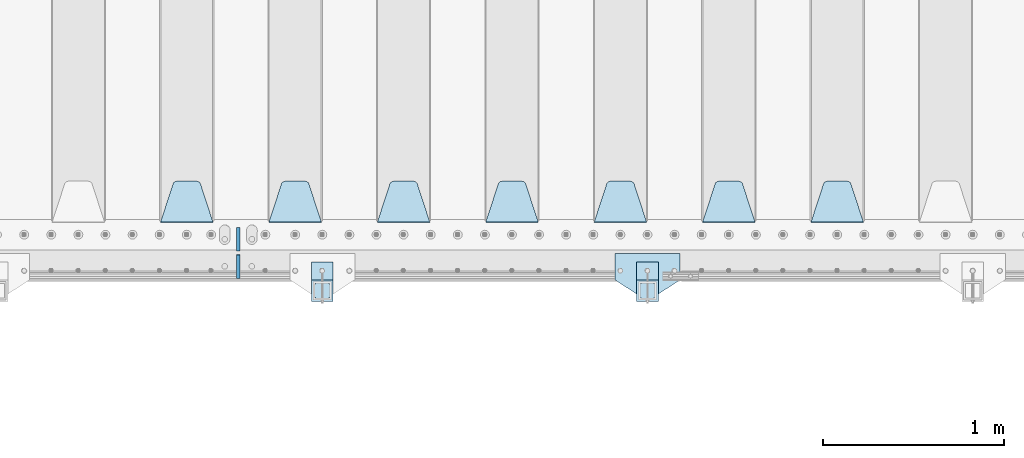
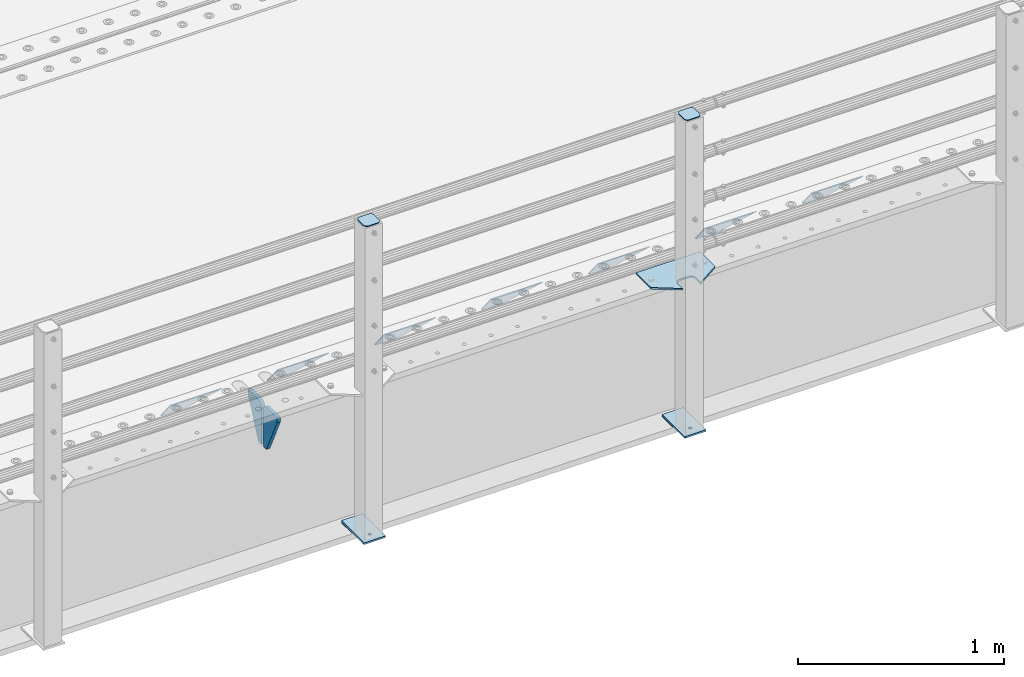
# One storey, part 205 of 242: 16 plates.
"""IFC2X3 building model written with IfcOpenShell, lengths in millimetres."""

from ifc_helpers import new_model, si_unit, frame, origin_with_axes, place, context, subcontext, project, spatial, faceted_brep, material, type_object, element, save


model = new_model("IFC2X3")

# Units and contexts
model_context = context("Model", 3, precision=1e-05, world=origin_with_axes())
body_context = subcontext(model_context, "Body", "Model", "MODEL_VIEW")
ifc_project = project(units=[si_unit("LENGTHUNIT", "METRE", prefix="MILLI"), si_unit("AREAUNIT", "SQUARE_METRE"), si_unit("VOLUMEUNIT", "CUBIC_METRE"), si_unit("MASSUNIT", "GRAM", prefix="KILO"), si_unit("TIMEUNIT", "SECOND"), si_unit("PLANEANGLEUNIT", "RADIAN"), si_unit("SOLIDANGLEUNIT", "STERADIAN"), si_unit("THERMODYNAMICTEMPERATUREUNIT", "DEGREE_CELSIUS"), si_unit("LUMINOUSINTENSITYUNIT", "LUMEN")], contexts=[model_context])

# Site, building, storey
site_placement = place(None, origin_with_axes())
site = spatial("IfcSite", under=ifc_project, at=site_placement, CompositionType="ELEMENT")
building_placement = place(site_placement, origin_with_axes())
building = spatial("IfcBuilding", under=site, at=building_placement, Name="Standard", CompositionType="ELEMENT")
storey_placement = place(building_placement, origin_with_axes())
storey = spatial("IfcBuildingStorey", under=building, at=storey_placement, Name="Undefined", CompositionType="ELEMENT", Elevation=0.0)

# Plates
ifc_material_1 = material(Name="STEEL/S355J2")
plate_type_1 = type_object("IfcPlateType", PredefinedType="NOTDEFINED")
plate_1_placement = place(storey_placement, frame((-32720.0, -24005.0, 5.00000000004911), z_axis=(0.0, -1.0, 0.0), x_axis=(-1.0, 0.0, 0.0)))
element("IfcPlate", 1, at=plate_1_placement, inside=storey, type_object=plate_type_1, material=ifc_material_1, context=body_context, shape_type="Brep", body=[
    faceted_brep([(0.0, -5.0, 0.0), (2.31396552408114e-06, -5.0, 145.0), (2.31396552408114e-06, 5.0, 145.0), (0.0, 5.0, 0.0), (130.0, -5.0, 230.0), (130.0, 5.0, 230.0), (130.0, -5.0, 180.0), (130.0, 5.0, 180.0), (130.48036798992, -5.0, 175.122741949595), (130.48036798992, 5.0, 175.122741949595), (131.903011687216, -5.0, 170.432914190871), (131.903011687216, 5.0, 170.432914190871), (134.213259692435, -5.0, 166.110744174512), (134.213259692435, 5.0, 166.110744174512), (137.322330470335, -5.0, 162.322330470335), (137.322330470335, 5.0, 162.322330470335), (141.110744174512, -5.0, 159.213259692435), (141.110744174512, 5.0, 159.213259692435), (145.432914190871, -5.0, 156.903011687216), (145.432914190871, 5.0, 156.903011687216), (150.122741949595, -5.0, 155.48036798992), (150.122741949595, 5.0, 155.48036798992), (155.0, -5.0, 155.0), (155.0, 5.0, 155.0), (205.0, -5.0, 155.0), (205.0, 5.0, 155.0), (209.877258050405, -5.0, 155.48036798992), (209.877258050405, 5.0, 155.48036798992), (214.567085809129, -5.0, 156.903011687216), (214.567085809129, 5.0, 156.903011687216), (218.889255825488, -5.0, 159.213259692435), (218.889255825488, 5.0, 159.213259692435), (222.677669529665, -5.0, 162.322330470335), (222.677669529665, 5.0, 162.322330470335), (225.786740307565, -5.0, 166.110744174512), (225.786740307565, 5.0, 166.110744174512), (228.096988312784, -5.0, 170.432914190871), (228.096988312784, 5.0, 170.432914190871), (229.51963201008, -5.0, 175.122741949595), (229.51963201008, 5.0, 175.122741949595), (230.0, -5.0, 180.0), (230.0, 5.0, 180.0), (230.0, -5.0, 230.0), (230.0, 5.0, 230.0), (360.0, -5.0, 145.0), (360.0, 5.0, 145.0), (360.0, -5.0, -7.27595761418343e-12), (360.0, 5.0, -7.27595761418343e-12)], [[[0, 1, 2, 3]], [[1, 4, 5, 2]], [[4, 6, 7, 5]], [[6, 8, 9, 7]], [[8, 10, 11, 9]], [[10, 12, 13, 11]], [[12, 14, 15, 13]], [[14, 16, 17, 15]], [[16, 18, 19, 17]], [[18, 20, 21, 19]], [[20, 22, 23, 21]], [[22, 24, 25, 23]], [[24, 26, 27, 25]], [[26, 28, 29, 27]], [[28, 30, 31, 29]], [[30, 32, 33, 31]], [[32, 34, 35, 33]], [[34, 36, 37, 35]], [[36, 38, 39, 37]], [[38, 40, 41, 39]], [[40, 42, 43, 41]], [[42, 44, 45, 43]], [[44, 46, 47, 45]], [[46, 0, 3, 47]], [[5, 7, 9, 11, 13, 15, 17, 19, 21, 23, 25, 27, 29, 31, 33, 35, 37, 39, 41, 43, 45, 47, 3, 2]], [[46, 44, 42, 40, 38, 36, 34, 32, 30, 28, 26, 24, 22, 20, 18, 16, 14, 12, 10, 8, 6, 4, 1, 0]]]),
])
plate_type_2 = type_object("IfcPlateType", PredefinedType="NOTDEFINED")
for number, where, z_axis, x_axis in (
    (2, (-32840.0000000001, -24050.0000000002, -850.000000000002), (0.0, -1.0, 0.0), (-1.0, 0.0, 0.0)),
    (3, (-34640.0000000001, -24050.0000000002, -850.000000000002), (0.0, -1.0, 0.0), (-1.0, 0.0, 0.0)),
):
    element("IfcPlate", number, at=place(storey_placement, frame(where, z_axis=z_axis, x_axis=x_axis)), inside=storey, type_object=plate_type_2, material=ifc_material_1, context=body_context, shape_type="Brep", body=[
        faceted_brep([(53.6360389691836, -5.0, 176.363961030471), (53.6360389691836, 5.0, 176.363961030471), (59.9999999998618, 5.0, 178.999999999793), (59.9999999998618, -5.0, 178.999999999793), (66.3639610305399, 5.0, 176.363961030471), (66.3639610305399, -5.0, 176.363961030471), (68.9999999998618, 5.0, 169.999999999793), (68.9999999998618, -5.0, 169.999999999793), (66.3639610305399, 5.0, 163.636038969114), (66.3639610305399, -5.0, 163.636038969114), (59.9999999998618, 5.0, 160.999999999793), (59.9999999998618, -5.0, 160.999999999793), (53.6360389691836, 5.0, 163.636038969114), (53.6360389691836, -5.0, 163.636038969114), (50.9999999998618, 5.0, 169.999999999793), (50.9999999998618, -5.0, 169.999999999793), (120.0, -5.0, 0.0), (120.0, -5.0, 220.0), (0.0, -5.0, 220.0), (0.0, -5.0, 0.0), (0.0, 5.0, 0.0), (120.0, 5.0, 0.0), (120.0, 5.0, 220.0), (0.0, 5.0, 220.0)], [[[0, 1, 2, 3]], [[3, 2, 4, 5]], [[5, 4, 6, 7]], [[7, 6, 8, 9]], [[9, 8, 10, 11]], [[11, 10, 12, 13]], [[13, 12, 14, 15]], [[15, 14, 1, 0]], [[16, 17, 18, 19], [3, 5, 7, 9, 11, 13, 15, 0]], [[16, 19, 20, 21]], [[17, 16, 21, 22]], [[18, 17, 22, 23]], [[19, 18, 23, 20]], [[22, 21, 20, 23], [10, 8, 6, 4, 2, 1, 14, 12]]]),
    ])
plate_type_3 = type_object("IfcPlateType", PredefinedType="NOTDEFINED")
plate_2_placement = place(storey_placement, frame((-32944.0000000001, -24166.0000000002, 1012.50000000001), z_axis=(0.0, -1.0, 0.0), x_axis=(1.0, 0.0, 0.0)))
element("IfcPlate", 4, at=plate_2_placement, inside=storey, type_object=plate_type_3, material=ifc_material_1, context=body_context, shape_type="Brep", body=[
    faceted_brep([(0.0, -2.5, 19.0), (0.0, -2.5, 69.0), (0.0, 2.5, 69.0), (0.0, 2.5, 19.0), (0.476369668544066, -2.5, 73.2278977451715), (0.476369668544066, 2.5, 73.2278977451715), (1.88159150985302, -2.5, 77.2437910432345), (1.88159150985302, 2.5, 77.2437910432345), (4.14520183310742, -2.5, 80.8463062353148), (4.14520183310742, 2.5, 80.8463062353148), (7.15369376468516, -2.5, 83.8547981668926), (7.15369376468516, 2.5, 83.8547981668926), (10.7562089567655, -2.5, 86.118408490147), (10.7562089567655, 2.5, 86.118408490147), (14.7721022548285, -2.5, 87.5236303314559), (14.7721022548285, 2.5, 87.5236303314559), (19.0, -2.5, 88.0), (19.0, 2.5, 88.0), (69.0, -2.5, 88.0), (69.0, 2.5, 88.0), (73.2278977451715, -2.5, 87.5236303314559), (73.2278977451715, 2.5, 87.5236303314559), (77.2437910432345, -2.5, 86.118408490147), (77.2437910432345, 2.5, 86.118408490147), (80.8463062353148, -2.5, 83.8547981668926), (80.8463062353148, 2.5, 83.8547981668926), (83.8547981668926, -2.5, 80.8463062353148), (83.8547981668926, 2.5, 80.8463062353148), (86.118408490147, -2.5, 77.2437910432345), (86.118408490147, 2.5, 77.2437910432345), (87.5236303314559, -2.5, 73.2278977451715), (87.5236303314559, 2.5, 73.2278977451715), (88.0, -2.5, 69.0), (88.0, 2.5, 69.0), (88.0, -2.5, 19.0), (88.0, 2.5, 19.0), (87.5236303314559, -2.5, 14.7721022548285), (87.5236303314559, 2.5, 14.7721022548285), (86.118408490147, -2.5, 10.7562089567655), (86.118408490147, 2.5, 10.7562089567655), (83.8547981668926, -2.5, 7.15369376468516), (83.8547981668926, 2.5, 7.15369376468516), (80.8463062353148, -2.5, 4.14520183310742), (80.8463062353148, 2.5, 4.14520183310742), (77.2437910432345, -2.5, 1.88159150985302), (77.2437910432345, 2.5, 1.88159150985302), (73.2278977451715, -2.5, 0.476369668544066), (73.2278977451715, 2.5, 0.476369668544066), (69.0, -2.5, 0.0), (69.0, 2.5, 0.0), (19.0, -2.5, 0.0), (19.0, 2.5, 0.0), (14.7721022548285, -2.5, 0.476369668544066), (14.7721022548285, 2.5, 0.476369668544066), (10.7562089567655, -2.5, 1.88159150985302), (10.7562089567655, 2.5, 1.88159150985302), (7.15369376468516, -2.5, 4.14520183310742), (7.15369376468516, 2.5, 4.14520183310742), (4.14520183310742, -2.5, 7.15369376468516), (4.14520183310742, 2.5, 7.15369376468516), (1.88159150985302, -2.5, 10.7562089567655), (1.88159150985302, 2.5, 10.7562089567655), (0.476369668544066, -2.5, 14.7721022548285), (0.476369668544066, 2.5, 14.7721022548285)], [[[0, 1, 2, 3]], [[1, 4, 5, 2]], [[4, 6, 7, 5]], [[6, 8, 9, 7]], [[8, 10, 11, 9]], [[10, 12, 13, 11]], [[12, 14, 15, 13]], [[14, 16, 17, 15]], [[16, 18, 19, 17]], [[18, 20, 21, 19]], [[20, 22, 23, 21]], [[22, 24, 25, 23]], [[24, 26, 27, 25]], [[26, 28, 29, 27]], [[28, 30, 31, 29]], [[30, 32, 33, 31]], [[32, 34, 35, 33]], [[34, 36, 37, 35]], [[36, 38, 39, 37]], [[38, 40, 41, 39]], [[40, 42, 43, 41]], [[42, 44, 45, 43]], [[44, 46, 47, 45]], [[46, 48, 49, 47]], [[48, 50, 51, 49]], [[50, 52, 53, 51]], [[52, 54, 55, 53]], [[54, 56, 57, 55]], [[56, 58, 59, 57]], [[58, 60, 61, 59]], [[60, 62, 63, 61]], [[62, 0, 3, 63]], [[5, 7, 9, 11, 13, 15, 17, 19, 21, 23, 25, 27, 29, 31, 33, 35, 37, 39, 41, 43, 45, 47, 49, 51, 53, 55, 57, 59, 61, 63, 3, 2]], [[62, 60, 58, 56, 54, 52, 50, 48, 46, 44, 42, 40, 38, 36, 34, 32, 30, 28, 26, 24, 22, 20, 18, 16, 14, 12, 10, 8, 6, 4, 1, 0]]]),
])
plate_3_placement = place(storey_placement, frame((-34744.0000000001, -24166.0000000002, 1012.50000000001), z_axis=(0.0, -1.0, 0.0), x_axis=(1.0, 0.0, 0.0)))
element("IfcPlate", 5, at=plate_3_placement, inside=storey, type_object=plate_type_3, material=ifc_material_1, context=body_context, shape_type="Brep", body=[
    faceted_brep([(0.0, -2.5, 19.0), (0.0, -2.5, 69.0), (0.0, 2.5, 69.0), (0.0, 2.5, 19.0), (0.476369668544066, -2.5, 73.2278977451715), (0.476369668544066, 2.5, 73.2278977451715), (1.88159150985302, -2.5, 77.2437910432345), (1.88159150985302, 2.5, 77.2437910432345), (4.14520183310742, -2.5, 80.8463062353148), (4.14520183310742, 2.5, 80.8463062353148), (7.15369376468516, -2.5, 83.8547981668926), (7.15369376468516, 2.5, 83.8547981668926), (10.7562089567655, -2.5, 86.118408490147), (10.7562089567655, 2.5, 86.118408490147), (14.7721022548285, -2.5, 87.5236303314559), (14.7721022548285, 2.5, 87.5236303314559), (19.0, -2.5, 88.0), (19.0, 2.5, 88.0), (69.0, -2.5, 88.0), (69.0, 2.5, 88.0), (73.2278977451715, -2.5, 87.5236303314559), (73.2278977451715, 2.5, 87.5236303314559), (77.2437910432345, -2.5, 86.118408490147), (77.2437910432345, 2.5, 86.118408490147), (80.8463062353148, -2.5, 83.8547981668926), (80.8463062353148, 2.5, 83.8547981668926), (83.8547981668926, -2.5, 80.8463062353148), (83.8547981668926, 2.5, 80.8463062353148), (86.118408490147, -2.5, 77.2437910432345), (86.118408490147, 2.5, 77.2437910432345), (87.5236303314559, -2.5, 73.2278977451715), (87.5236303314559, 2.5, 73.2278977451715), (88.0, -2.5, 69.0), (88.0, 2.5, 69.0), (88.0, -2.5, 19.0), (88.0, 2.5, 19.0), (87.5236303314559, -2.5, 14.7721022548285), (87.5236303314559, 2.5, 14.7721022548285), (86.118408490147, -2.5, 10.7562089567655), (86.118408490147, 2.5, 10.7562089567655), (83.8547981668926, -2.5, 7.15369376468516), (83.8547981668926, 2.5, 7.15369376468516), (80.8463062353148, -2.5, 4.14520183310742), (80.8463062353148, 2.5, 4.14520183310742), (77.2437910432345, -2.5, 1.88159150985302), (77.2437910432345, 2.5, 1.88159150985302), (73.2278977451715, -2.5, 0.476369668544066), (73.2278977451715, 2.5, 0.476369668544066), (69.0, -2.5, 0.0), (69.0, 2.5, 0.0), (19.0, -2.5, 0.0), (19.0, 2.5, 0.0), (14.7721022548285, -2.5, 0.476369668544066), (14.7721022548285, 2.5, 0.476369668544066), (10.7562089567655, -2.5, 1.88159150985302), (10.7562089567655, 2.5, 1.88159150985302), (7.15369376468516, -2.5, 4.14520183310742), (7.15369376468516, 2.5, 4.14520183310742), (4.14520183310742, -2.5, 7.15369376468516), (4.14520183310742, 2.5, 7.15369376468516), (1.88159150985302, -2.5, 10.7562089567655), (1.88159150985302, 2.5, 10.7562089567655), (0.476369668544066, -2.5, 14.7721022548285), (0.476369668544066, 2.5, 14.7721022548285)], [[[0, 1, 2, 3]], [[1, 4, 5, 2]], [[4, 6, 7, 5]], [[6, 8, 9, 7]], [[8, 10, 11, 9]], [[10, 12, 13, 11]], [[12, 14, 15, 13]], [[14, 16, 17, 15]], [[16, 18, 19, 17]], [[18, 20, 21, 19]], [[20, 22, 23, 21]], [[22, 24, 25, 23]], [[24, 26, 27, 25]], [[26, 28, 29, 27]], [[28, 30, 31, 29]], [[30, 32, 33, 31]], [[32, 34, 35, 33]], [[34, 36, 37, 35]], [[36, 38, 39, 37]], [[38, 40, 41, 39]], [[40, 42, 43, 41]], [[42, 44, 45, 43]], [[44, 46, 47, 45]], [[46, 48, 49, 47]], [[48, 50, 51, 49]], [[50, 52, 53, 51]], [[52, 54, 55, 53]], [[54, 56, 57, 55]], [[56, 58, 59, 57]], [[58, 60, 61, 59]], [[60, 62, 63, 61]], [[62, 0, 3, 63]], [[5, 7, 9, 11, 13, 15, 17, 19, 21, 23, 25, 27, 29, 31, 33, 35, 37, 39, 41, 43, 45, 47, 49, 51, 53, 55, 57, 59, 61, 63, 3, 2]], [[62, 60, 58, 56, 54, 52, 50, 48, 46, 44, 42, 40, 38, 36, 34, 32, 30, 28, 26, 24, 22, 20, 18, 16, 14, 12, 10, 8, 6, 4, 1, 0]]]),
])
plate_type_4 = type_object("IfcPlateType", PredefinedType="NOTDEFINED")
for number, where, z_axis, x_axis in (
    (6, (-32840.0000000001, -24050.0000000002, -857.500000000002), (0.0, -1.0, 0.0), (-1.0, 0.0, 0.0)),
    (7, (-34640.0000000001, -24050.0000000002, -857.500000000002), (0.0, -1.0, 0.0), (-1.0, 0.0, 0.0)),
):
    element("IfcPlate", number, at=place(storey_placement, frame(where, z_axis=z_axis, x_axis=x_axis)), inside=storey, type_object=plate_type_4, material=ifc_material_1, context=body_context, shape_type="Brep", body=[
        faceted_brep([(0.0, -2.5, 0.0), (0.0, -2.5, 100.0), (0.0, 2.5, 100.0), (0.0, 2.5, 0.0), (120.0, -2.5, 100.0), (120.0, 2.5, 100.0), (120.0, -2.5, 0.0), (120.0, 2.5, 0.0)], [[[0, 1, 2, 3]], [[1, 4, 5, 2]], [[4, 6, 7, 5]], [[6, 0, 3, 7]], [[5, 7, 3, 2]], [[6, 4, 1, 0]]]),
    ])
ifc_material_2 = material(Name="STEEL/S355N")
plate_type_5 = type_object("IfcPlateType", PredefinedType="NOTDEFINED")
plate_4_placement = place(storey_placement, frame((-31705.0, -23831.767766953, -1.76776695296758), z_axis=(0.0, 0.707106781186547, -0.707106781186548), x_axis=(-1.0, 0.0, 0.0)))
element("IfcPlate", 8, at=plate_4_placement, inside=storey, type_object=plate_type_5, material=ifc_material_2, context=body_context, shape_type="Brep", body=[
    faceted_brep([(0.0, -2.5, 0.0), (69.345504679477, -2.50000000000182, 300.171731424829), (69.345504679477, 2.5, 300.171731424829), (0.0, 2.5, 0.0), (70.9274061199576, -2.5, 304.897442415398), (70.9274061199576, 2.5, 304.897442415398), (73.3818627772307, -2.5, 309.234538108525), (73.3818627772307, 2.50000000000182, 309.234538108529), (76.6187032999551, -2.5, 313.023683126101), (76.6187032999551, 2.50000000000182, 313.023683126103), (80.5190132704993, -2.5, 316.12567259537), (80.5190132704993, 2.5, 316.12567259537), (84.9395038596849, -2.5, 318.426546230474), (84.9395038596849, 2.50000000000182, 318.426546230476), (89.7177759439219, -2.49999999999818, 319.841774983273), (89.7177759439219, 2.50000000000182, 319.841774983273), (94.678286292652, -2.5, 320.319366455076), (94.678286292652, 2.5, 320.319366455076), (195.321713707348, -2.5, 320.319366455076), (195.321713707348, 2.5, 320.319366455076), (200.282224056078, -2.5, 319.841774983272), (200.282224056078, 2.50000000000182, 319.841774983273), (205.060496140315, -2.5, 318.426546230474), (205.060496140315, 2.49999999999818, 318.426546230474), (209.480986729501, -2.49999999999818, 316.12567259537), (209.480986729501, 2.5, 316.12567259537), (213.381296700045, -2.5, 313.023683126101), (213.381296700045, 2.49999999999818, 313.023683126101), (216.618137222769, -2.5, 309.234538108525), (216.618137222769, 2.5, 309.234538108523), (219.072593880042, -2.49999999999818, 304.897442415398), (219.072593880042, 2.50000000000182, 304.897442415398), (220.654495320523, -2.50000000000182, 300.171731424829), (220.654495320523, 2.5, 300.171731424829), (290.0, -2.5, 0.0), (290.0, 2.5, -1.81898940354586e-12)], [[[0, 1, 2, 3]], [[1, 4, 5, 2]], [[4, 6, 7, 5]], [[6, 8, 9, 7]], [[8, 10, 11, 9]], [[10, 12, 13, 11]], [[12, 14, 15, 13]], [[14, 16, 17, 15]], [[16, 18, 19, 17]], [[18, 20, 21, 19]], [[20, 22, 23, 21]], [[22, 24, 25, 23]], [[24, 26, 27, 25]], [[26, 28, 29, 27]], [[28, 30, 31, 29]], [[30, 32, 33, 31]], [[32, 34, 35, 33]], [[34, 0, 3, 35]], [[5, 7, 9, 11, 13, 15, 17, 19, 21, 23, 25, 27, 29, 31, 33, 35, 3, 2]], [[34, 32, 30, 28, 26, 24, 22, 20, 18, 16, 14, 12, 10, 8, 6, 4, 1, 0]]]),
])
plate_5_placement = place(storey_placement, frame((-32305.0, -23831.767766953, -1.76776695296758), z_axis=(0.0, 0.707106781186547, -0.707106781186548), x_axis=(-1.0, 0.0, 0.0)))
element("IfcPlate", 9, at=plate_5_placement, inside=storey, type_object=plate_type_5, material=ifc_material_2, context=body_context, shape_type="Brep", body=[
    faceted_brep([(0.0, -2.5, 0.0), (69.345504679477, -2.50000000000182, 300.171731424829), (69.345504679477, 2.5, 300.171731424829), (0.0, 2.5, 0.0), (70.9274061199576, -2.5, 304.897442415398), (70.9274061199576, 2.5, 304.897442415398), (73.3818627772307, -2.5, 309.234538108525), (73.3818627772307, 2.50000000000182, 309.234538108529), (76.6187032999551, -2.5, 313.023683126101), (76.6187032999551, 2.50000000000182, 313.023683126103), (80.5190132704993, -2.5, 316.12567259537), (80.5190132704993, 2.5, 316.12567259537), (84.9395038596849, -2.5, 318.426546230474), (84.9395038596849, 2.50000000000182, 318.426546230476), (89.7177759439219, -2.49999999999818, 319.841774983273), (89.7177759439219, 2.50000000000182, 319.841774983273), (94.678286292652, -2.5, 320.319366455076), (94.678286292652, 2.5, 320.319366455076), (195.321713707348, -2.5, 320.319366455076), (195.321713707348, 2.5, 320.319366455076), (200.282224056078, -2.5, 319.841774983272), (200.282224056078, 2.50000000000182, 319.841774983273), (205.060496140315, -2.5, 318.426546230474), (205.060496140315, 2.49999999999818, 318.426546230474), (209.480986729501, -2.49999999999818, 316.12567259537), (209.480986729501, 2.5, 316.12567259537), (213.381296700045, -2.5, 313.023683126101), (213.381296700045, 2.49999999999818, 313.023683126101), (216.618137222769, -2.5, 309.234538108525), (216.618137222769, 2.5, 309.234538108523), (219.072593880042, -2.49999999999818, 304.897442415398), (219.072593880042, 2.50000000000182, 304.897442415398), (220.654495320523, -2.50000000000182, 300.171731424829), (220.654495320523, 2.5, 300.171731424829), (290.0, -2.5, 0.0), (290.0, 2.5, -1.81898940354586e-12)], [[[0, 1, 2, 3]], [[1, 4, 5, 2]], [[4, 6, 7, 5]], [[6, 8, 9, 7]], [[8, 10, 11, 9]], [[10, 12, 13, 11]], [[12, 14, 15, 13]], [[14, 16, 17, 15]], [[16, 18, 19, 17]], [[18, 20, 21, 19]], [[20, 22, 23, 21]], [[22, 24, 25, 23]], [[24, 26, 27, 25]], [[26, 28, 29, 27]], [[28, 30, 31, 29]], [[30, 32, 33, 31]], [[32, 34, 35, 33]], [[34, 0, 3, 35]], [[5, 7, 9, 11, 13, 15, 17, 19, 21, 23, 25, 27, 29, 31, 33, 35, 3, 2]], [[34, 32, 30, 28, 26, 24, 22, 20, 18, 16, 14, 12, 10, 8, 6, 4, 1, 0]]]),
])
plate_6_placement = place(storey_placement, frame((-32905.0, -23831.767766953, -1.76776695296758), z_axis=(0.0, 0.707106781186547, -0.707106781186548), x_axis=(-1.0, 0.0, 0.0)))
element("IfcPlate", 10, at=plate_6_placement, inside=storey, type_object=plate_type_5, material=ifc_material_2, context=body_context, shape_type="Brep", body=[
    faceted_brep([(0.0, -2.5, 0.0), (69.345504679477, -2.50000000000182, 300.171731424829), (69.345504679477, 2.5, 300.171731424829), (0.0, 2.5, 0.0), (70.9274061199576, -2.5, 304.897442415398), (70.9274061199576, 2.5, 304.897442415398), (73.3818627772307, -2.5, 309.234538108525), (73.3818627772307, 2.50000000000182, 309.234538108529), (76.6187032999551, -2.5, 313.023683126101), (76.6187032999551, 2.50000000000182, 313.023683126103), (80.5190132704993, -2.5, 316.12567259537), (80.5190132704993, 2.5, 316.12567259537), (84.9395038596849, -2.5, 318.426546230474), (84.9395038596849, 2.50000000000182, 318.426546230476), (89.7177759439219, -2.49999999999818, 319.841774983273), (89.7177759439219, 2.50000000000182, 319.841774983273), (94.678286292652, -2.5, 320.319366455076), (94.678286292652, 2.5, 320.319366455076), (195.321713707348, -2.5, 320.319366455076), (195.321713707348, 2.5, 320.319366455076), (200.282224056078, -2.5, 319.841774983272), (200.282224056078, 2.50000000000182, 319.841774983273), (205.060496140315, -2.5, 318.426546230474), (205.060496140315, 2.49999999999818, 318.426546230474), (209.480986729501, -2.49999999999818, 316.12567259537), (209.480986729501, 2.5, 316.12567259537), (213.381296700045, -2.5, 313.023683126101), (213.381296700045, 2.49999999999818, 313.023683126101), (216.618137222769, -2.5, 309.234538108525), (216.618137222769, 2.5, 309.234538108523), (219.072593880042, -2.49999999999818, 304.897442415398), (219.072593880042, 2.50000000000182, 304.897442415398), (220.654495320523, -2.50000000000182, 300.171731424829), (220.654495320523, 2.5, 300.171731424829), (290.0, -2.5, 0.0), (290.0, 2.5, -1.81898940354586e-12)], [[[0, 1, 2, 3]], [[1, 4, 5, 2]], [[4, 6, 7, 5]], [[6, 8, 9, 7]], [[8, 10, 11, 9]], [[10, 12, 13, 11]], [[12, 14, 15, 13]], [[14, 16, 17, 15]], [[16, 18, 19, 17]], [[18, 20, 21, 19]], [[20, 22, 23, 21]], [[22, 24, 25, 23]], [[24, 26, 27, 25]], [[26, 28, 29, 27]], [[28, 30, 31, 29]], [[30, 32, 33, 31]], [[32, 34, 35, 33]], [[34, 0, 3, 35]], [[5, 7, 9, 11, 13, 15, 17, 19, 21, 23, 25, 27, 29, 31, 33, 35, 3, 2]], [[34, 32, 30, 28, 26, 24, 22, 20, 18, 16, 14, 12, 10, 8, 6, 4, 1, 0]]]),
])
plate_7_placement = place(storey_placement, frame((-33505.0, -23831.767766953, -1.76776695296758), z_axis=(0.0, 0.707106781186547, -0.707106781186548), x_axis=(-1.0, 0.0, 0.0)))
element("IfcPlate", 11, at=plate_7_placement, inside=storey, type_object=plate_type_5, material=ifc_material_2, context=body_context, shape_type="Brep", body=[
    faceted_brep([(0.0, -2.5, 0.0), (69.345504679477, -2.50000000000182, 300.171731424829), (69.345504679477, 2.5, 300.171731424829), (0.0, 2.5, 0.0), (70.9274061199576, -2.5, 304.897442415398), (70.9274061199576, 2.5, 304.897442415398), (73.3818627772307, -2.5, 309.234538108525), (73.3818627772307, 2.50000000000182, 309.234538108529), (76.6187032999551, -2.5, 313.023683126101), (76.6187032999551, 2.50000000000182, 313.023683126103), (80.5190132704993, -2.5, 316.12567259537), (80.5190132704993, 2.5, 316.12567259537), (84.9395038596849, -2.5, 318.426546230474), (84.9395038596849, 2.50000000000182, 318.426546230476), (89.7177759439219, -2.49999999999818, 319.841774983273), (89.7177759439219, 2.50000000000182, 319.841774983273), (94.678286292652, -2.5, 320.319366455076), (94.678286292652, 2.5, 320.319366455076), (195.321713707348, -2.5, 320.319366455076), (195.321713707348, 2.5, 320.319366455076), (200.282224056078, -2.5, 319.841774983272), (200.282224056078, 2.50000000000182, 319.841774983273), (205.060496140315, -2.5, 318.426546230474), (205.060496140315, 2.49999999999818, 318.426546230474), (209.480986729501, -2.49999999999818, 316.12567259537), (209.480986729501, 2.5, 316.12567259537), (213.381296700045, -2.5, 313.023683126101), (213.381296700045, 2.49999999999818, 313.023683126101), (216.618137222769, -2.5, 309.234538108525), (216.618137222769, 2.5, 309.234538108523), (219.072593880042, -2.49999999999818, 304.897442415398), (219.072593880042, 2.50000000000182, 304.897442415398), (220.654495320523, -2.50000000000182, 300.171731424829), (220.654495320523, 2.5, 300.171731424829), (290.0, -2.5, 0.0), (290.0, 2.5, -1.81898940354586e-12)], [[[0, 1, 2, 3]], [[1, 4, 5, 2]], [[4, 6, 7, 5]], [[6, 8, 9, 7]], [[8, 10, 11, 9]], [[10, 12, 13, 11]], [[12, 14, 15, 13]], [[14, 16, 17, 15]], [[16, 18, 19, 17]], [[18, 20, 21, 19]], [[20, 22, 23, 21]], [[22, 24, 25, 23]], [[24, 26, 27, 25]], [[26, 28, 29, 27]], [[28, 30, 31, 29]], [[30, 32, 33, 31]], [[32, 34, 35, 33]], [[34, 0, 3, 35]], [[5, 7, 9, 11, 13, 15, 17, 19, 21, 23, 25, 27, 29, 31, 33, 35, 3, 2]], [[34, 32, 30, 28, 26, 24, 22, 20, 18, 16, 14, 12, 10, 8, 6, 4, 1, 0]]]),
])
plate_8_placement = place(storey_placement, frame((-34105.0, -23831.767766953, -1.76776695296758), z_axis=(0.0, 0.707106781186547, -0.707106781186548), x_axis=(-1.0, 0.0, 0.0)))
element("IfcPlate", 12, at=plate_8_placement, inside=storey, type_object=plate_type_5, material=ifc_material_2, context=body_context, shape_type="Brep", body=[
    faceted_brep([(0.0, -2.5, 0.0), (69.345504679477, -2.50000000000182, 300.171731424829), (69.345504679477, 2.5, 300.171731424829), (0.0, 2.5, 0.0), (70.9274061199576, -2.5, 304.897442415398), (70.9274061199576, 2.5, 304.897442415398), (73.3818627772307, -2.5, 309.234538108525), (73.3818627772307, 2.50000000000182, 309.234538108529), (76.6187032999551, -2.5, 313.023683126101), (76.6187032999551, 2.50000000000182, 313.023683126103), (80.5190132704993, -2.5, 316.12567259537), (80.5190132704993, 2.5, 316.12567259537), (84.9395038596849, -2.5, 318.426546230474), (84.9395038596849, 2.50000000000182, 318.426546230476), (89.7177759439219, -2.49999999999818, 319.841774983273), (89.7177759439219, 2.50000000000182, 319.841774983273), (94.678286292652, -2.5, 320.319366455076), (94.678286292652, 2.5, 320.319366455076), (195.321713707348, -2.5, 320.319366455076), (195.321713707348, 2.5, 320.319366455076), (200.282224056078, -2.5, 319.841774983272), (200.282224056078, 2.50000000000182, 319.841774983273), (205.060496140315, -2.5, 318.426546230474), (205.060496140315, 2.49999999999818, 318.426546230474), (209.480986729501, -2.49999999999818, 316.12567259537), (209.480986729501, 2.5, 316.12567259537), (213.381296700045, -2.5, 313.023683126101), (213.381296700045, 2.49999999999818, 313.023683126101), (216.618137222769, -2.5, 309.234538108525), (216.618137222769, 2.5, 309.234538108523), (219.072593880042, -2.49999999999818, 304.897442415398), (219.072593880042, 2.50000000000182, 304.897442415398), (220.654495320523, -2.50000000000182, 300.171731424829), (220.654495320523, 2.5, 300.171731424829), (290.0, -2.5, 0.0), (290.0, 2.5, -1.81898940354586e-12)], [[[0, 1, 2, 3]], [[1, 4, 5, 2]], [[4, 6, 7, 5]], [[6, 8, 9, 7]], [[8, 10, 11, 9]], [[10, 12, 13, 11]], [[12, 14, 15, 13]], [[14, 16, 17, 15]], [[16, 18, 19, 17]], [[18, 20, 21, 19]], [[20, 22, 23, 21]], [[22, 24, 25, 23]], [[24, 26, 27, 25]], [[26, 28, 29, 27]], [[28, 30, 31, 29]], [[30, 32, 33, 31]], [[32, 34, 35, 33]], [[34, 0, 3, 35]], [[5, 7, 9, 11, 13, 15, 17, 19, 21, 23, 25, 27, 29, 31, 33, 35, 3, 2]], [[34, 32, 30, 28, 26, 24, 22, 20, 18, 16, 14, 12, 10, 8, 6, 4, 1, 0]]]),
])
plate_9_placement = place(storey_placement, frame((-34705.0, -23831.767766953, -1.76776695296758), z_axis=(0.0, 0.707106781186547, -0.707106781186548), x_axis=(-1.0, 0.0, 0.0)))
element("IfcPlate", 13, at=plate_9_placement, inside=storey, type_object=plate_type_5, material=ifc_material_2, context=body_context, shape_type="Brep", body=[
    faceted_brep([(0.0, -2.5, 0.0), (69.345504679477, -2.50000000000182, 300.171731424829), (69.345504679477, 2.5, 300.171731424829), (0.0, 2.5, 0.0), (70.9274061199576, -2.5, 304.897442415398), (70.9274061199576, 2.5, 304.897442415398), (73.3818627772307, -2.5, 309.234538108525), (73.3818627772307, 2.50000000000182, 309.234538108529), (76.6187032999551, -2.5, 313.023683126101), (76.6187032999551, 2.50000000000182, 313.023683126103), (80.5190132704993, -2.5, 316.12567259537), (80.5190132704993, 2.5, 316.12567259537), (84.9395038596849, -2.5, 318.426546230474), (84.9395038596849, 2.50000000000182, 318.426546230476), (89.7177759439219, -2.49999999999818, 319.841774983273), (89.7177759439219, 2.50000000000182, 319.841774983273), (94.678286292652, -2.5, 320.319366455076), (94.678286292652, 2.5, 320.319366455076), (195.321713707348, -2.5, 320.319366455076), (195.321713707348, 2.5, 320.319366455076), (200.282224056078, -2.5, 319.841774983272), (200.282224056078, 2.50000000000182, 319.841774983273), (205.060496140315, -2.5, 318.426546230474), (205.060496140315, 2.49999999999818, 318.426546230474), (209.480986729501, -2.49999999999818, 316.12567259537), (209.480986729501, 2.5, 316.12567259537), (213.381296700045, -2.5, 313.023683126101), (213.381296700045, 2.49999999999818, 313.023683126101), (216.618137222769, -2.5, 309.234538108525), (216.618137222769, 2.5, 309.234538108523), (219.072593880042, -2.49999999999818, 304.897442415398), (219.072593880042, 2.50000000000182, 304.897442415398), (220.654495320523, -2.50000000000182, 300.171731424829), (220.654495320523, 2.5, 300.171731424829), (290.0, -2.5, 0.0), (290.0, 2.5, -1.81898940354586e-12)], [[[0, 1, 2, 3]], [[1, 4, 5, 2]], [[4, 6, 7, 5]], [[6, 8, 9, 7]], [[8, 10, 11, 9]], [[10, 12, 13, 11]], [[12, 14, 15, 13]], [[14, 16, 17, 15]], [[16, 18, 19, 17]], [[18, 20, 21, 19]], [[20, 22, 23, 21]], [[22, 24, 25, 23]], [[24, 26, 27, 25]], [[26, 28, 29, 27]], [[28, 30, 31, 29]], [[30, 32, 33, 31]], [[32, 34, 35, 33]], [[34, 0, 3, 35]], [[5, 7, 9, 11, 13, 15, 17, 19, 21, 23, 25, 27, 29, 31, 33, 35, 3, 2]], [[34, 32, 30, 28, 26, 24, 22, 20, 18, 16, 14, 12, 10, 8, 6, 4, 1, 0]]]),
])
plate_10_placement = place(storey_placement, frame((-35305.0, -23831.767766953, -1.76776695296758), z_axis=(0.0, 0.707106781186547, -0.707106781186548), x_axis=(-1.0, 0.0, 0.0)))
element("IfcPlate", 14, at=plate_10_placement, inside=storey, type_object=plate_type_5, material=ifc_material_2, context=body_context, shape_type="Brep", body=[
    faceted_brep([(0.0, -2.5, 0.0), (69.345504679477, -2.50000000000182, 300.171731424829), (69.345504679477, 2.5, 300.171731424829), (0.0, 2.5, 0.0), (70.9274061199576, -2.5, 304.897442415398), (70.9274061199576, 2.5, 304.897442415398), (73.3818627772307, -2.5, 309.234538108525), (73.3818627772307, 2.50000000000182, 309.234538108529), (76.6187032999551, -2.5, 313.023683126101), (76.6187032999551, 2.50000000000182, 313.023683126103), (80.5190132704993, -2.5, 316.12567259537), (80.5190132704993, 2.5, 316.12567259537), (84.9395038596849, -2.5, 318.426546230474), (84.9395038596849, 2.50000000000182, 318.426546230476), (89.7177759439219, -2.49999999999818, 319.841774983273), (89.7177759439219, 2.50000000000182, 319.841774983273), (94.678286292652, -2.5, 320.319366455076), (94.678286292652, 2.5, 320.319366455076), (195.321713707348, -2.5, 320.319366455076), (195.321713707348, 2.5, 320.319366455076), (200.282224056078, -2.5, 319.841774983272), (200.282224056078, 2.50000000000182, 319.841774983273), (205.060496140315, -2.5, 318.426546230474), (205.060496140315, 2.49999999999818, 318.426546230474), (209.480986729501, -2.49999999999818, 316.12567259537), (209.480986729501, 2.5, 316.12567259537), (213.381296700045, -2.5, 313.023683126101), (213.381296700045, 2.49999999999818, 313.023683126101), (216.618137222769, -2.5, 309.234538108525), (216.618137222769, 2.5, 309.234538108523), (219.072593880042, -2.49999999999818, 304.897442415398), (219.072593880042, 2.50000000000182, 304.897442415398), (220.654495320523, -2.50000000000182, 300.171731424829), (220.654495320523, 2.5, 300.171731424829), (290.0, -2.5, 0.0), (290.0, 2.5, -1.81898940354586e-12)], [[[0, 1, 2, 3]], [[1, 4, 5, 2]], [[4, 6, 7, 5]], [[6, 8, 9, 7]], [[8, 10, 11, 9]], [[10, 12, 13, 11]], [[12, 14, 15, 13]], [[14, 16, 17, 15]], [[16, 18, 19, 17]], [[18, 20, 21, 19]], [[20, 22, 23, 21]], [[22, 24, 25, 23]], [[24, 26, 27, 25]], [[26, 28, 29, 27]], [[28, 30, 31, 29]], [[30, 32, 33, 31]], [[32, 34, 35, 33]], [[34, 0, 3, 35]], [[5, 7, 9, 11, 13, 15, 17, 19, 21, 23, 25, 27, 29, 31, 33, 35, 3, 2]], [[34, 32, 30, 28, 26, 24, 22, 20, 18, 16, 14, 12, 10, 8, 6, 4, 1, 0]]]),
])
plate_type_6 = type_object("IfcPlateType", PredefinedType="NOTDEFINED")
for number, where, z_axis, x_axis in (
    (15, (-35165.0, -23858.75, -35.0), (0.0, 0.0, -1.0), (0.0, -1.0, 0.0)),
    (16, (-35165.0, -24141.25, -35.0), (0.0, 0.0, -1.0), (0.0, 1.0, 0.0)),
):
    element("IfcPlate", number, at=place(storey_placement, frame(where, z_axis=z_axis, x_axis=x_axis)), inside=storey, type_object=plate_type_6, material=ifc_material_2, context=body_context, shape_type="Brep", body=[
        faceted_brep([(0.0, -10.0, 0.0), (0.0, -10.0, 30.0), (0.0, 10.0, 30.0), (0.0, 10.0, 0.0), (102.0, -10.0, 250.0), (102.0, 10.0, 250.0), (132.0, -10.0, 250.0), (132.0, 10.0, 250.0), (132.0, -10.0, 30.0), (132.0, 10.0, 30.0), (131.544232590368, -10.0, 24.790554669992), (131.544232590368, 10.0, 24.790554669992), (130.190778623579, -10.0, 19.7393957002299), (130.190778623579, 10.0, 19.7393957002299), (127.980762113533, -10.0, 15.0), (127.980762113533, 10.0, 15.0), (124.98133329357, -10.0, 10.7163717094038), (124.98133329357, 10.0, 10.7163717094038), (121.283628290596, -10.0, 7.01866670643062), (121.283628290596, 10.0, 7.01866670643062), (117.0, -10.0, 4.01923788646684), (117.0, 10.0, 4.01923788646684), (112.260604299769, -10.0, 1.80922137642278), (112.260604299769, 10.0, 1.80922137642278), (107.209445330009, -10.0, 0.455767409633722), (107.209445330009, 10.0, 0.455767409633722), (102.0, -10.0, 0.0), (102.0, 10.0, 0.0)], [[[0, 1, 2, 3]], [[1, 4, 5, 2]], [[4, 6, 7, 5]], [[6, 8, 9, 7]], [[8, 10, 11, 9]], [[10, 12, 13, 11]], [[12, 14, 15, 13]], [[14, 16, 17, 15]], [[16, 18, 19, 17]], [[18, 20, 21, 19]], [[20, 22, 23, 21]], [[22, 24, 25, 23]], [[24, 26, 27, 25]], [[26, 0, 3, 27]], [[5, 7, 9, 11, 13, 15, 17, 19, 21, 23, 25, 27, 3, 2]], [[26, 24, 22, 20, 18, 16, 14, 12, 10, 8, 6, 4, 1, 0]]]),
    ])

save(model, "model.ifc")
